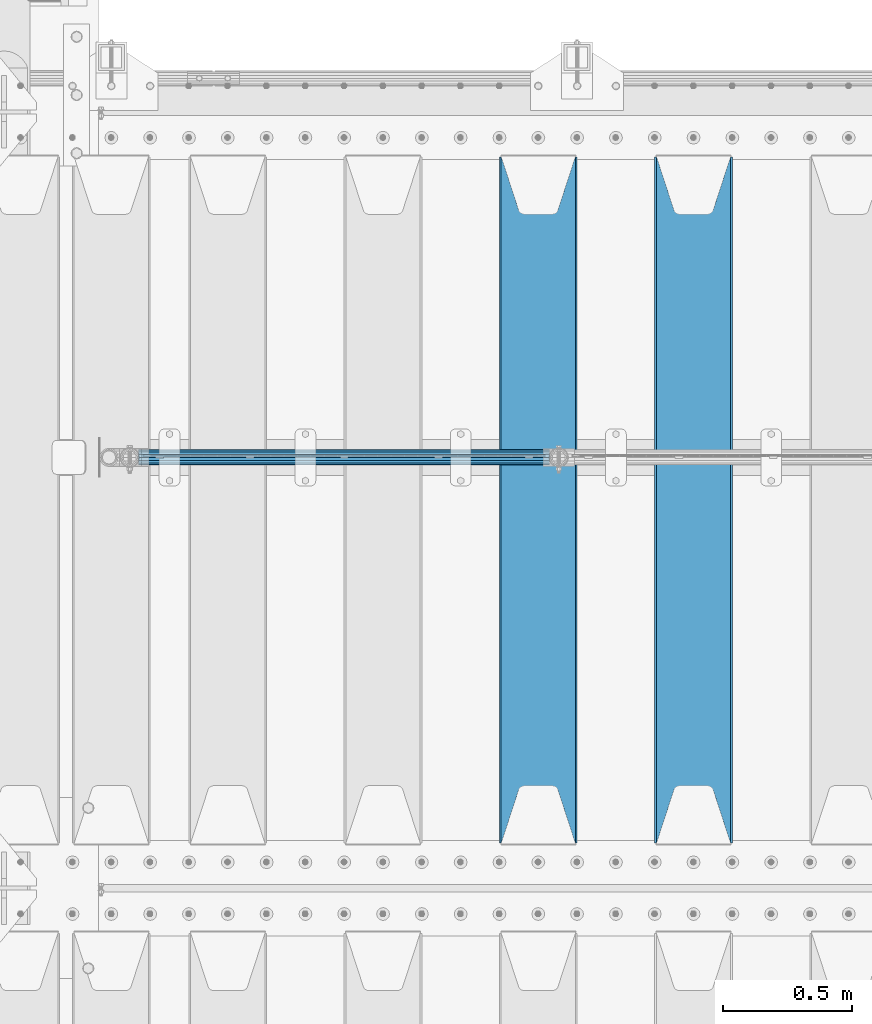
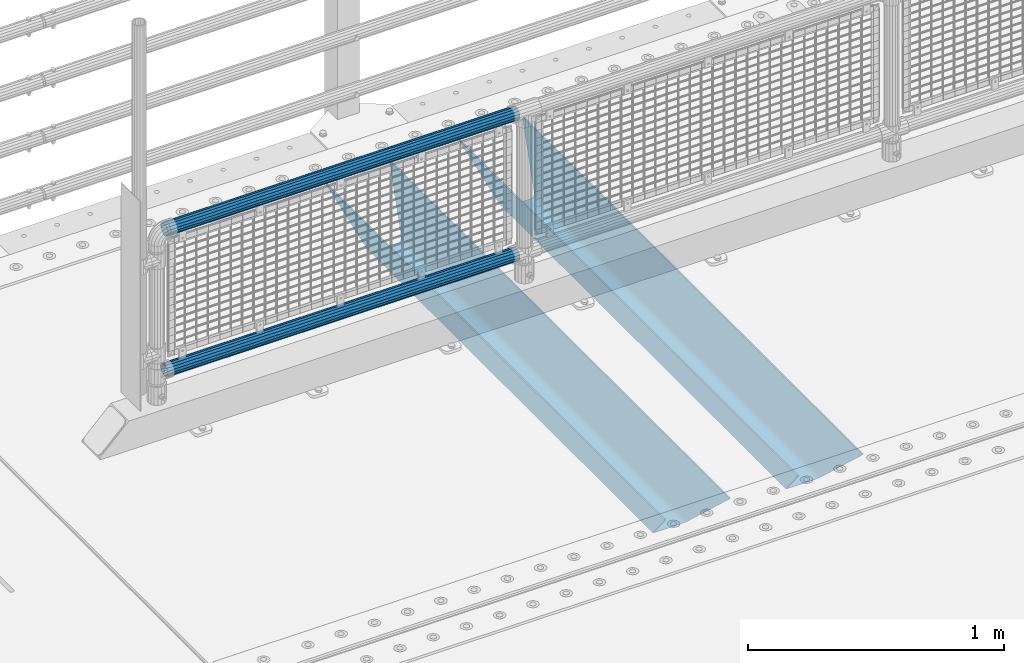
# One storey, part 89 of 193: 4 beams.
"""IFC2X3 building model written with IfcOpenShell, lengths in millimetres."""

from ifc_helpers import new_model, si_unit, frame, origin_with_axes, place, context, subcontext, project, spatial, faceted_brep, material, type_object, element, save


model = new_model("IFC2X3")

# Units and contexts
model_context = context("Model", 3, precision=1e-05, world=origin_with_axes())
body_context = subcontext(model_context, "Body", "Model", "MODEL_VIEW")
ifc_project = project(units=[si_unit("LENGTHUNIT", "METRE", prefix="MILLI"), si_unit("AREAUNIT", "SQUARE_METRE"), si_unit("VOLUMEUNIT", "CUBIC_METRE"), si_unit("MASSUNIT", "GRAM", prefix="KILO"), si_unit("TIMEUNIT", "SECOND"), si_unit("PLANEANGLEUNIT", "RADIAN"), si_unit("SOLIDANGLEUNIT", "STERADIAN"), si_unit("THERMODYNAMICTEMPERATUREUNIT", "DEGREE_CELSIUS"), si_unit("LUMINOUSINTENSITYUNIT", "LUMEN")], contexts=[model_context])

# Site, building, storey
site_placement = place(None, origin_with_axes())
site = spatial("IfcSite", under=ifc_project, at=site_placement, CompositionType="ELEMENT")
building_placement = place(site_placement, origin_with_axes())
building = spatial("IfcBuilding", under=site, at=building_placement, Name="Standard", CompositionType="ELEMENT")
storey_placement = place(building_placement, origin_with_axes())
storey = spatial("IfcBuildingStorey", under=building, at=storey_placement, Name="Undefined", CompositionType="ELEMENT", Elevation=0.0)

# Beams
ifc_material_1 = material(Name="STEEL/S355N")
beam_type_1 = type_object("IfcBeamType", PredefinedType="NOTDEFINED")
beam_1_placement = place(storey_placement, frame((-39650.0, 27175.0, -115.0), z_axis=(0.0, 0.0, 1.0), x_axis=(0.0, 1.0, 0.0)))
element("IfcBeam", 1, at=beam_1_placement, inside=storey, type_object=beam_type_1, material=ifc_material_1, context=body_context, shape_type="Brep", body=[
    faceted_brep([(0.0, 150.0, 115.0), (0.0, 143.689999999999, 115.0), (2650.00000000297, 143.689999999999, 115.0), (2650.00000000297, 150.0, 115.0), (2650.00000000297, 142.059565218398, 110.000000003094), (2650.00000000297, 148.3695652184, 110.000000003094), (2441.90079219209, -80.1103600731112, -98.0992078077845), (2437.7588105432, -77.5672621345584, -102.241189456673), (2434.06523489747, -74.4080125315522, -105.934765102404), (2430.9108609509, -70.710272125576, -109.089139048974), (2428.37322971128, -66.5649389910068, -111.626770288588), (2426.51472138055, -62.0739139532889, -113.485278619323), (2425.38102192092, -57.3475956567672, -114.618978078955), (2424.99999999988, -52.5021667386536, -115.0), (2424.99999999988, 52.5021667386536, -115.0), (2425.38102192092, 57.3475956567672, -114.618978078955), (2426.51472138055, 62.0739139532889, -113.485278619323), (2428.37322971128, 66.5649389910068, -111.626770288588), (2430.9108609509, 70.710272125576, -109.089139048974), (2434.06523489747, 74.4080125315522, -105.934765102404), (2437.7588105432, 77.5672621345584, -102.241189456673), (2441.90079219209, 80.1103600731112, -98.0992078077846), (2446.38936140512, 81.9747917625791, -93.6106385947584), (2448.2494850041, 76.2713538057251, -91.7505149957729), (2444.62967112263, 74.76777986261, -95.3703288772456), (2441.28936334127, 72.7168944282894, -98.710636658607), (2438.31067330439, 70.1691124903846, -101.689326695487), (2435.76682334748, 67.1870637758839, -104.233176652398), (2433.72034654134, 63.8440531834895, -106.279653458539), (2432.22154950042, 60.222258798236, -107.778450499454), (2431.30727574265, 56.4107117849089, -108.692724257221), (2430.99999999987, 52.5031078186876, -109.0), (2430.99999999987, -52.5031078186876, -109.0), (2431.30727574265, -56.4107117849089, -108.692724257221), (2432.22154950042, -60.222258798236, -107.778450499454), (2433.72034654134, -63.8440531834895, -106.279653458539), (2435.76682334748, -67.1870637758839, -104.233176652398), (2438.31067330439, -70.1691124903846, -101.689326695487), (2441.28936334127, -72.7168944282894, -98.7106366586071), (2444.62967112263, -74.76777986261, -95.3703288772457), (2448.2494850041, -76.2713538057251, -91.7505149957729), (2650.00000000297, -142.059565218398, 110.000000003094), (2650.00000000297, -148.3695652184, 110.000000003094), (2446.38936140512, -81.9747917625791, -93.6106385947584), (2650.00000000297, -143.689999999999, 115.0), (2650.00000000297, -150.0, 115.0), (0.0, -143.689999999999, 115.0), (0.0, -150.0, 115.0), (0.0, -148.369565218261, 110.000000002667), (203.610638597427, -81.9747917625791, -93.6106385947584), (208.099207810446, -80.1103600731112, -98.0992078077845), (212.241189459342, -77.5672621345584, -102.241189456673), (215.93476510507, -74.4080125315522, -105.934765102404), (219.089139051641, -70.710272125576, -109.089139048974), (221.626770291256, -66.5649389910068, -111.626770288588), (223.485278621989, -62.0739139532889, -113.485278619323), (224.618978081624, -57.3475956567672, -114.618978078955), (225.000000002663, -52.5021667386536, -115.0), (225.000000002663, 52.5021667386536, -115.0), (224.618978081624, 57.3475956567672, -114.618978078955), (223.485278621989, 62.0739139532889, -113.485278619323), (221.626770291256, 66.5649389910068, -111.626770288588), (219.089139051641, 70.710272125576, -109.089139048974), (215.93476510507, 74.4080125315522, -105.934765102404), (212.241189459342, 77.5672621345584, -102.241189456673), (208.099207810446, 80.1103600731112, -98.0992078077846), (203.610638597427, 81.9747917625791, -93.6106385947584), (0.0, 148.369565218261, 110.000000002667), (0.0, 142.05956521826, 110.000000002667), (201.750514998439, 76.2713538057251, -91.7505149957729), (205.370328879915, 74.76777986261, -95.3703288772456), (208.710636661275, 72.7168944282894, -98.710636658607), (211.689326698157, 70.1691124903846, -101.689326695487), (214.233176655063, 67.1870637758839, -104.233176652398), (216.279653461206, 63.8440531834895, -106.279653458539), (217.778450502123, 60.222258798236, -107.778450499454), (218.69272425989, 56.4107117849089, -108.692724257221), (219.00000000267, 52.5031078186876, -109.0), (219.00000000267, -52.5031078186876, -109.0), (218.69272425989, -56.4107117849089, -108.692724257221), (217.778450502123, -60.222258798236, -107.778450499454), (216.279653461206, -63.8440531834895, -106.279653458539), (214.233176655063, -67.1870637758839, -104.233176652398), (211.689326698157, -70.1691124903846, -101.689326695487), (208.710636661275, -72.7168944282894, -98.7106366586071), (205.370328879915, -74.76777986261, -95.3703288772457), (201.750514998439, -76.2713538057251, -91.7505149957729), (0.0, -142.05956521826, 110.000000002667)], [[[0, 1, 2, 3]], [[3, 2, 4, 5]], [[6, 7, 8, 9, 10, 11, 12, 13, 14, 15, 16, 17, 18, 19, 20, 21, 22, 5, 4, 23, 24, 25, 26, 27, 28, 29, 30, 31, 32, 33, 34, 35, 36, 37, 38, 39, 40, 41, 42, 43]], [[44, 45, 42, 41]], [[46, 47, 45, 44]], [[43, 42, 45, 47, 48, 49]], [[6, 43, 49, 50]], [[7, 6, 50, 51]], [[8, 7, 51, 52]], [[9, 8, 52, 53]], [[10, 9, 53, 54]], [[11, 10, 54, 55]], [[12, 11, 55, 56]], [[13, 12, 56, 57]], [[14, 13, 57, 58]], [[15, 14, 58, 59]], [[16, 15, 59, 60]], [[17, 16, 60, 61]], [[18, 17, 61, 62]], [[19, 18, 62, 63]], [[20, 19, 63, 64]], [[21, 20, 64, 65]], [[22, 21, 65, 66]], [[0, 3, 5, 22, 66, 67]], [[1, 0, 67, 68]], [[23, 4, 2, 1, 68, 69]], [[24, 23, 69, 70]], [[25, 24, 70, 71]], [[26, 25, 71, 72]], [[27, 26, 72, 73]], [[28, 27, 73, 74]], [[29, 28, 74, 75]], [[30, 29, 75, 76]], [[31, 30, 76, 77]], [[32, 31, 77, 78]], [[33, 32, 78, 79]], [[34, 33, 79, 80]], [[35, 34, 80, 81]], [[36, 35, 81, 82]], [[37, 36, 82, 83]], [[38, 37, 83, 84]], [[39, 38, 84, 85]], [[40, 39, 85, 86]], [[46, 44, 41, 40, 86, 87]], [[47, 46, 87, 48]], [[86, 85, 84, 83, 82, 81, 80, 79, 78, 77, 76, 75, 74, 73, 72, 71, 70, 69, 68, 67, 66, 65, 64, 63, 62, 61, 60, 59, 58, 57, 56, 55, 54, 53, 52, 51, 50, 49, 48, 87]]]),
])
beam_2_placement = place(storey_placement, frame((-40250.0, 27175.0, -115.0), z_axis=(0.0, 0.0, 1.0), x_axis=(0.0, 1.0, 0.0)))
element("IfcBeam", 2, at=beam_2_placement, inside=storey, type_object=beam_type_1, material=ifc_material_1, context=body_context, shape_type="Brep", body=[
    faceted_brep([(0.0, 150.0, 115.0), (0.0, 143.689999999999, 115.0), (2650.00000000297, 143.689999999999, 115.0), (2650.00000000297, 150.0, 115.0), (2650.00000000297, 142.059565218398, 110.000000003094), (2650.00000000297, 148.3695652184, 110.000000003094), (2441.90079219209, -80.1103600731112, -98.0992078077845), (2437.7588105432, -77.5672621345584, -102.241189456673), (2434.06523489747, -74.4080125315522, -105.934765102404), (2430.9108609509, -70.710272125576, -109.089139048974), (2428.37322971128, -66.5649389910068, -111.626770288588), (2426.51472138055, -62.0739139532889, -113.485278619323), (2425.38102192092, -57.3475956567672, -114.618978078955), (2424.99999999988, -52.5021667386536, -115.0), (2424.99999999988, 52.5021667386536, -115.0), (2425.38102192092, 57.3475956567672, -114.618978078955), (2426.51472138055, 62.0739139532889, -113.485278619323), (2428.37322971128, 66.5649389910068, -111.626770288588), (2430.9108609509, 70.710272125576, -109.089139048974), (2434.06523489747, 74.4080125315522, -105.934765102404), (2437.7588105432, 77.5672621345584, -102.241189456673), (2441.90079219209, 80.1103600731112, -98.0992078077846), (2446.38936140512, 81.9747917625791, -93.6106385947584), (2448.2494850041, 76.2713538057251, -91.7505149957729), (2444.62967112263, 74.76777986261, -95.3703288772456), (2441.28936334127, 72.7168944282894, -98.710636658607), (2438.31067330439, 70.1691124903846, -101.689326695487), (2435.76682334748, 67.1870637758839, -104.233176652398), (2433.72034654134, 63.8440531834895, -106.279653458539), (2432.22154950042, 60.222258798236, -107.778450499454), (2431.30727574265, 56.4107117849089, -108.692724257221), (2430.99999999987, 52.5031078186876, -109.0), (2430.99999999987, -52.5031078186876, -109.0), (2431.30727574265, -56.4107117849089, -108.692724257221), (2432.22154950042, -60.222258798236, -107.778450499454), (2433.72034654134, -63.8440531834895, -106.279653458539), (2435.76682334748, -67.1870637758839, -104.233176652398), (2438.31067330439, -70.1691124903846, -101.689326695487), (2441.28936334127, -72.7168944282894, -98.7106366586071), (2444.62967112263, -74.76777986261, -95.3703288772457), (2448.2494850041, -76.2713538057251, -91.7505149957729), (2650.00000000297, -142.059565218398, 110.000000003094), (2650.00000000297, -148.3695652184, 110.000000003094), (2446.38936140512, -81.9747917625791, -93.6106385947584), (2650.00000000297, -143.689999999999, 115.0), (2650.00000000297, -150.0, 115.0), (0.0, -143.689999999999, 115.0), (0.0, -150.0, 115.0), (0.0, -148.369565218261, 110.000000002667), (203.610638597427, -81.9747917625791, -93.6106385947584), (208.099207810446, -80.1103600731112, -98.0992078077845), (212.241189459342, -77.5672621345584, -102.241189456673), (215.93476510507, -74.4080125315522, -105.934765102404), (219.089139051641, -70.710272125576, -109.089139048974), (221.626770291256, -66.5649389910068, -111.626770288588), (223.485278621989, -62.0739139532889, -113.485278619323), (224.618978081624, -57.3475956567672, -114.618978078955), (225.000000002663, -52.5021667386536, -115.0), (225.000000002663, 52.5021667386536, -115.0), (224.618978081624, 57.3475956567672, -114.618978078955), (223.485278621989, 62.0739139532889, -113.485278619323), (221.626770291256, 66.5649389910068, -111.626770288588), (219.089139051641, 70.710272125576, -109.089139048974), (215.93476510507, 74.4080125315522, -105.934765102404), (212.241189459342, 77.5672621345584, -102.241189456673), (208.099207810446, 80.1103600731112, -98.0992078077846), (203.610638597427, 81.9747917625791, -93.6106385947584), (0.0, 148.369565218261, 110.000000002667), (0.0, 142.05956521826, 110.000000002667), (201.750514998439, 76.2713538057251, -91.7505149957729), (205.370328879915, 74.76777986261, -95.3703288772456), (208.710636661275, 72.7168944282894, -98.710636658607), (211.689326698157, 70.1691124903846, -101.689326695487), (214.233176655063, 67.1870637758839, -104.233176652398), (216.279653461206, 63.8440531834895, -106.279653458539), (217.778450502123, 60.222258798236, -107.778450499454), (218.69272425989, 56.4107117849089, -108.692724257221), (219.00000000267, 52.5031078186876, -109.0), (219.00000000267, -52.5031078186876, -109.0), (218.69272425989, -56.4107117849089, -108.692724257221), (217.778450502123, -60.222258798236, -107.778450499454), (216.279653461206, -63.8440531834895, -106.279653458539), (214.233176655063, -67.1870637758839, -104.233176652398), (211.689326698157, -70.1691124903846, -101.689326695487), (208.710636661275, -72.7168944282894, -98.7106366586071), (205.370328879915, -74.76777986261, -95.3703288772457), (201.750514998439, -76.2713538057251, -91.7505149957729), (0.0, -142.05956521826, 110.000000002667)], [[[0, 1, 2, 3]], [[3, 2, 4, 5]], [[6, 7, 8, 9, 10, 11, 12, 13, 14, 15, 16, 17, 18, 19, 20, 21, 22, 5, 4, 23, 24, 25, 26, 27, 28, 29, 30, 31, 32, 33, 34, 35, 36, 37, 38, 39, 40, 41, 42, 43]], [[44, 45, 42, 41]], [[46, 47, 45, 44]], [[43, 42, 45, 47, 48, 49]], [[6, 43, 49, 50]], [[7, 6, 50, 51]], [[8, 7, 51, 52]], [[9, 8, 52, 53]], [[10, 9, 53, 54]], [[11, 10, 54, 55]], [[12, 11, 55, 56]], [[13, 12, 56, 57]], [[14, 13, 57, 58]], [[15, 14, 58, 59]], [[16, 15, 59, 60]], [[17, 16, 60, 61]], [[18, 17, 61, 62]], [[19, 18, 62, 63]], [[20, 19, 63, 64]], [[21, 20, 64, 65]], [[22, 21, 65, 66]], [[0, 3, 5, 22, 66, 67]], [[1, 0, 67, 68]], [[23, 4, 2, 1, 68, 69]], [[24, 23, 69, 70]], [[25, 24, 70, 71]], [[26, 25, 71, 72]], [[27, 26, 72, 73]], [[28, 27, 73, 74]], [[29, 28, 74, 75]], [[30, 29, 75, 76]], [[31, 30, 76, 77]], [[32, 31, 77, 78]], [[33, 32, 78, 79]], [[34, 33, 79, 80]], [[35, 34, 80, 81]], [[36, 35, 81, 82]], [[37, 36, 82, 83]], [[38, 37, 83, 84]], [[39, 38, 84, 85]], [[40, 39, 85, 86]], [[46, 44, 41, 40, 86, 87]], [[47, 46, 87, 48]], [[86, 85, 84, 83, 82, 81, 80, 79, 78, 77, 76, 75, 74, 73, 72, 71, 70, 69, 68, 67, 66, 65, 64, 63, 62, 61, 60, 59, 58, 57, 56, 55, 54, 53, 52, 51, 50, 49, 48, 87]]]),
])
ifc_material_2 = material()
beam_type_2 = type_object("IfcBeamType", PredefinedType="NOTDEFINED")
beam_3_placement = place(storey_placement, frame((-41794.15, 28664.5, 969.849999999999), z_axis=(0.0, 0.0, 1.0), x_axis=(1.0, 0.0, 0.0)))
element("IfcBeam", 3, at=beam_3_placement, inside=storey, type_object=beam_type_2, material=ifc_material_2, context=body_context, shape_type="Brep", body=[
    faceted_brep([(0.0, -25.3499999999985, 0.0), (0.0, -23.4203461491597, 9.70102501045403), (1588.0, -23.4203461491597, 9.70102501045506), (1588.0, -25.3499999999985, 0.0), (0.0, -17.9251569030785, 17.9251569030785), (1588.0, -17.9251569030785, 17.925156903079), (0.0, -9.70102501045403, 23.4203461491597), (1588.0, -9.70102501045403, 23.4203461491611), (0.0, 0.0, 25.3499999999985), (1588.0, 0.0, 25.35), (0.0, 9.70102501045403, 23.4203461491597), (1588.0, 9.70102501045403, 23.4203461491611), (0.0, 17.9251569030785, 17.9251569030785), (1588.0, 17.9251569030785, 17.925156903079), (0.0, 23.4203461491597, 9.70102501045403), (1588.0, 23.4203461491597, 9.70102501045506), (0.0, 25.3499999999985, 0.0), (1588.0, 25.3499999999985, 0.0), (0.0, 23.4203461491597, -9.70102501045403), (1588.0, 23.4203461491597, -9.70102501045506), (0.0, 17.9251569030785, -17.9251569030785), (1588.0, 17.9251569030785, -17.925156903079), (0.0, 9.70102501045403, -23.4203461491597), (1588.0, 9.70102501045403, -23.4203461491611), (0.0, 0.0, -25.3499999999985), (1588.0, 0.0, -25.35), (0.0, -9.70102501045403, -23.4203461491597), (1588.0, -9.70102501045403, -23.4203461491611), (0.0, -17.9251569030785, -17.9251569030785), (1588.0, -17.9251569030785, -17.925156903079), (0.0, -23.4203461491597, -9.70102501045403), (1588.0, -23.4203461491597, -9.70102501045506), (0.0, -30.1500000000015, 0.0), (0.0, -27.8549679052157, -11.5379054858058), (1588.0, -27.8549679052157, -11.5379054858075), (1588.0, -30.1500000000015, 0.0), (0.0, -21.3192694527752, -21.3192694527752), (1588.0, -21.3192694527752, -21.3192694527744), (0.0, -11.5379054858058, -27.8549679052157), (1588.0, -11.5379054858058, -27.8549679052153), (0.0, 0.0, -30.1500000000015), (1588.0, 0.0, -30.15), (0.0, 11.5379054858058, -27.8549679052157), (1588.0, 11.5379054858058, -27.8549679052153), (0.0, 21.3192694527752, -21.3192694527752), (1588.0, 21.3192694527752, -21.3192694527744), (0.0, 27.8549679052157, -11.5379054858058), (1588.0, 27.8549679052157, -11.5379054858074), (0.0, 30.1500000000015, 0.0), (1588.0, 30.1500000000015, 0.0), (0.0, 27.8549679052157, 11.5379054858058), (1588.0, 27.8549679052157, 11.5379054858074), (0.0, 21.3192694527752, 21.3192694527752), (1588.0, 21.3192694527752, 21.3192694527744), (0.0, 11.5379054858058, 27.8549679052157), (1588.0, 11.5379054858058, 27.8549679052153), (0.0, 0.0, 30.1500000000015), (1588.0, 0.0, 30.15), (0.0, -11.5379054858058, 27.8549679052157), (1588.0, -11.5379054858058, 27.8549679052153), (0.0, -21.3192694527752, 21.3192694527752), (1588.0, -21.3192694527752, 21.3192694527744), (0.0, -27.8549679052157, 11.5379054858058), (1588.0, -27.8549679052157, 11.5379054858074)], [[[0, 1, 2, 3]], [[1, 4, 5, 2]], [[4, 6, 7, 5]], [[6, 8, 9, 7]], [[8, 10, 11, 9]], [[10, 12, 13, 11]], [[12, 14, 15, 13]], [[14, 16, 17, 15]], [[16, 18, 19, 17]], [[18, 20, 21, 19]], [[20, 22, 23, 21]], [[22, 24, 25, 23]], [[24, 26, 27, 25]], [[26, 28, 29, 27]], [[28, 30, 31, 29]], [[30, 0, 3, 31]], [[32, 33, 34, 35]], [[33, 36, 37, 34]], [[36, 38, 39, 37]], [[38, 40, 41, 39]], [[40, 42, 43, 41]], [[42, 44, 45, 43]], [[44, 46, 47, 45]], [[46, 48, 49, 47]], [[48, 50, 51, 49]], [[50, 52, 53, 51]], [[52, 54, 55, 53]], [[54, 56, 57, 55]], [[56, 58, 59, 57]], [[58, 60, 61, 59]], [[60, 62, 63, 61]], [[62, 32, 35, 63]], [[37, 39, 41, 43, 45, 47, 49, 51, 53, 55, 57, 59, 61, 63, 35, 34], [5, 7, 9, 11, 13, 15, 17, 19, 21, 23, 25, 27, 29, 31, 3, 2]], [[62, 60, 58, 56, 54, 52, 50, 48, 46, 44, 42, 40, 38, 36, 33, 32], [30, 28, 26, 24, 22, 20, 18, 16, 14, 12, 10, 8, 6, 4, 1, 0]]]),
])
beam_4_placement = place(storey_placement, frame((-41794.15, 28664.5, 298.170000000001), z_axis=(0.0, 0.0, 1.0), x_axis=(1.0, 0.0, 0.0)))
element("IfcBeam", 4, at=beam_4_placement, inside=storey, type_object=beam_type_2, material=ifc_material_2, context=body_context, shape_type="Brep", body=[
    faceted_brep([(0.0, -25.3499999999985, 0.0), (0.0, -23.4203461491597, 9.70102501045403), (1588.0, -23.4203461491597, 9.70102501045506), (1588.0, -25.3499999999985, 0.0), (0.0, -17.9251569030785, 17.9251569030785), (1588.0, -17.9251569030785, 17.925156903079), (0.0, -9.70102501045403, 23.4203461491597), (1588.0, -9.70102501045403, 23.4203461491611), (0.0, 0.0, 25.3499999999985), (1588.0, 0.0, 25.35), (0.0, 9.70102501045403, 23.4203461491597), (1588.0, 9.70102501045403, 23.4203461491611), (0.0, 17.9251569030785, 17.9251569030785), (1588.0, 17.9251569030785, 17.925156903079), (0.0, 23.4203461491597, 9.70102501045403), (1588.0, 23.4203461491597, 9.70102501045506), (0.0, 25.3499999999985, 0.0), (1588.0, 25.3499999999985, 0.0), (0.0, 23.4203461491597, -9.70102501045403), (1588.0, 23.4203461491597, -9.70102501045506), (0.0, 17.9251569030785, -17.9251569030785), (1588.0, 17.9251569030785, -17.925156903079), (0.0, 9.70102501045403, -23.4203461491597), (1588.0, 9.70102501045403, -23.4203461491611), (0.0, 0.0, -25.3499999999985), (1588.0, 0.0, -25.35), (0.0, -9.70102501045403, -23.4203461491597), (1588.0, -9.70102501045403, -23.4203461491611), (0.0, -17.9251569030785, -17.9251569030785), (1588.0, -17.9251569030785, -17.925156903079), (0.0, -23.4203461491597, -9.70102501045403), (1588.0, -23.4203461491597, -9.70102501045506), (0.0, -30.1500000000015, 0.0), (0.0, -27.8549679052157, -11.5379054858058), (1588.0, -27.8549679052157, -11.5379054858075), (1588.0, -30.1500000000015, 0.0), (0.0, -21.3192694527752, -21.3192694527752), (1588.0, -21.3192694527752, -21.3192694527744), (0.0, -11.5379054858058, -27.8549679052157), (1588.0, -11.5379054858058, -27.8549679052153), (0.0, 0.0, -30.1500000000015), (1588.0, 0.0, -30.15), (0.0, 11.5379054858058, -27.8549679052157), (1588.0, 11.5379054858058, -27.8549679052153), (0.0, 21.3192694527752, -21.3192694527752), (1588.0, 21.3192694527752, -21.3192694527744), (0.0, 27.8549679052157, -11.5379054858058), (1588.0, 27.8549679052157, -11.5379054858074), (0.0, 30.1500000000015, 0.0), (1588.0, 30.1500000000015, 0.0), (0.0, 27.8549679052157, 11.5379054858058), (1588.0, 27.8549679052157, 11.5379054858074), (0.0, 21.3192694527752, 21.3192694527752), (1588.0, 21.3192694527752, 21.3192694527744), (0.0, 11.5379054858058, 27.8549679052157), (1588.0, 11.5379054858058, 27.8549679052153), (0.0, 0.0, 30.1500000000015), (1588.0, 0.0, 30.15), (0.0, -11.5379054858058, 27.8549679052157), (1588.0, -11.5379054858058, 27.8549679052153), (0.0, -21.3192694527752, 21.3192694527752), (1588.0, -21.3192694527752, 21.3192694527744), (0.0, -27.8549679052157, 11.5379054858058), (1588.0, -27.8549679052157, 11.5379054858074)], [[[0, 1, 2, 3]], [[1, 4, 5, 2]], [[4, 6, 7, 5]], [[6, 8, 9, 7]], [[8, 10, 11, 9]], [[10, 12, 13, 11]], [[12, 14, 15, 13]], [[14, 16, 17, 15]], [[16, 18, 19, 17]], [[18, 20, 21, 19]], [[20, 22, 23, 21]], [[22, 24, 25, 23]], [[24, 26, 27, 25]], [[26, 28, 29, 27]], [[28, 30, 31, 29]], [[30, 0, 3, 31]], [[32, 33, 34, 35]], [[33, 36, 37, 34]], [[36, 38, 39, 37]], [[38, 40, 41, 39]], [[40, 42, 43, 41]], [[42, 44, 45, 43]], [[44, 46, 47, 45]], [[46, 48, 49, 47]], [[48, 50, 51, 49]], [[50, 52, 53, 51]], [[52, 54, 55, 53]], [[54, 56, 57, 55]], [[56, 58, 59, 57]], [[58, 60, 61, 59]], [[60, 62, 63, 61]], [[62, 32, 35, 63]], [[37, 39, 41, 43, 45, 47, 49, 51, 53, 55, 57, 59, 61, 63, 35, 34], [5, 7, 9, 11, 13, 15, 17, 19, 21, 23, 25, 27, 29, 31, 3, 2]], [[62, 60, 58, 56, 54, 52, 50, 48, 46, 44, 42, 40, 38, 36, 33, 32], [30, 28, 26, 24, 22, 20, 18, 16, 14, 12, 10, 8, 6, 4, 1, 0]]]),
])

save(model, "model.ifc")
